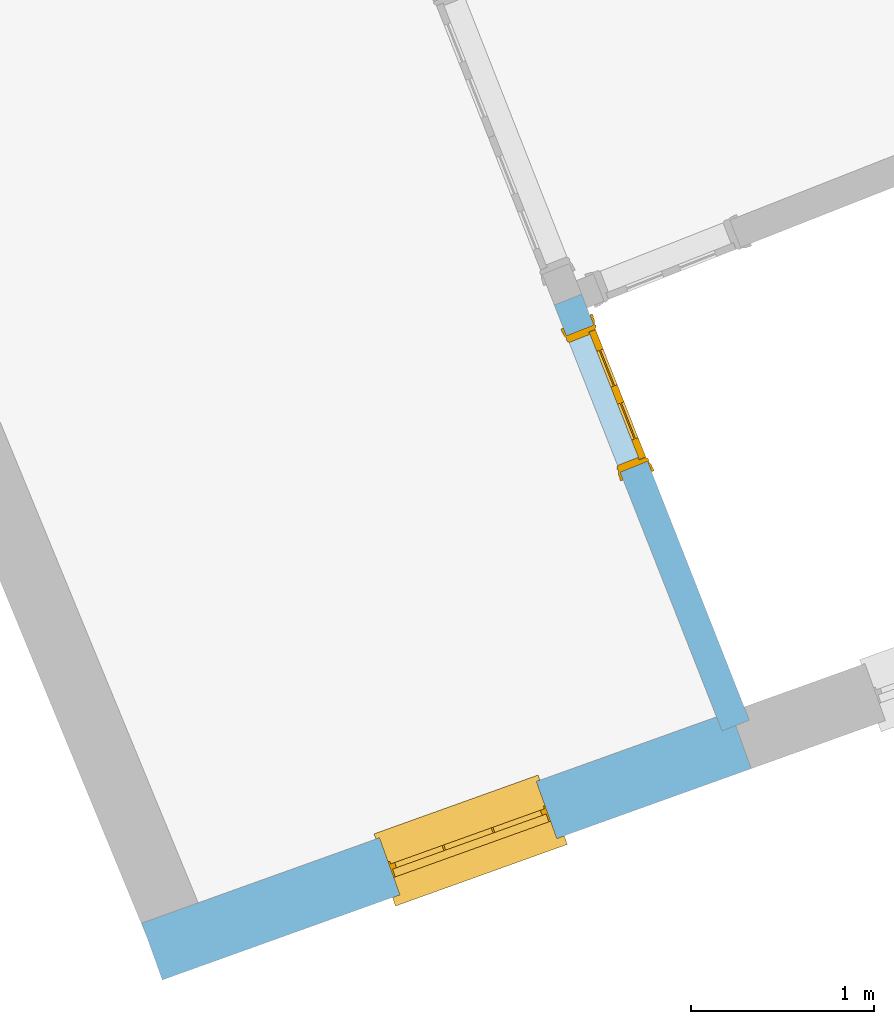
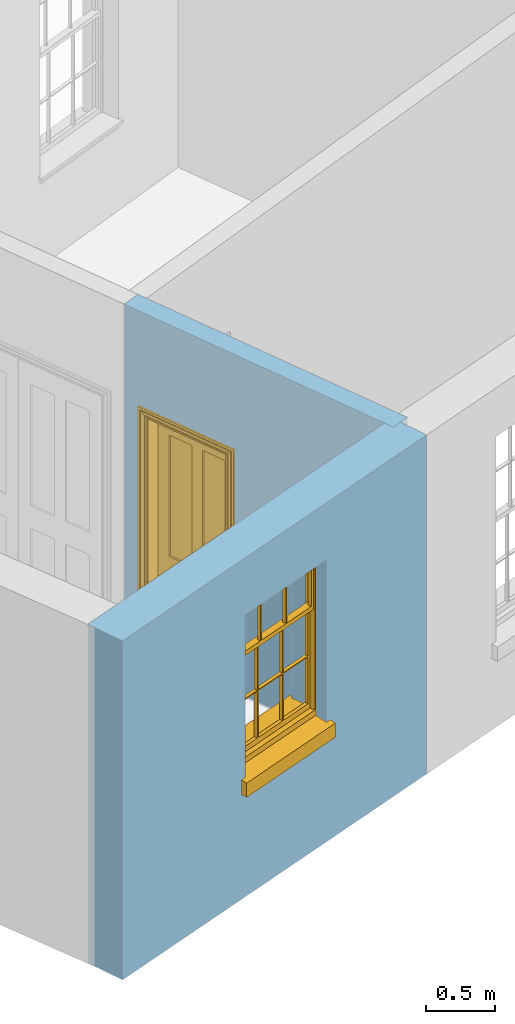
# One storey, part 2 of 6: 1 door, 1 window, 2 openings, plus 2 elements that do not belong to this part.
"""IFC2X3 building model written with IfcOpenShell, lengths in metres."""

from ifc_helpers import new_model, si_unit, frame, origin, place, context, subcontext, project, spatial, polyline, outline, extrude, faceted_brep, material, layer, layer_set, layer_usage, element, fill, save


model = new_model("IFC2X3")

# Units and contexts
model_context = context("Model", 3, world=origin())
body_context = subcontext(model_context, "Body", "Model", "MODEL_VIEW")
ifc_project = project(units=[si_unit("PLANEANGLEUNIT", "RADIAN"), si_unit("MASSUNIT", "GRAM", prefix="KILO"), si_unit("FORCEUNIT", "NEWTON", prefix="KILO"), si_unit("LENGTHUNIT", "METRE")], contexts=[model_context])

# Site, building, storey
site_placement = place(None, origin())
site = spatial("IfcSite", under=ifc_project, at=site_placement, CompositionType="ELEMENT")
building_placement = place(None, origin())
building = spatial("IfcBuilding", under=site, at=building_placement, Name="Building plot-4", CompositionType="ELEMENT")
storey_placement = place(None, frame((0.0, 0.0, 6.45)))
storey = spatial("IfcBuildingStorey", under=building, at=storey_placement, Name="Floor 1", CompositionType="ELEMENT", Elevation=6.45)

# Wall, opening, window
ifc_material_1 = material(Name="Masonry")
ifc_layer_1 = layer(ifc_material_1, 0.33, ventilated=False)
ifc_layer_set_1 = layer_set([ifc_layer_1], Name="My Wall")
ifc_layer_usage_1 = layer_usage(ifc_layer_set_1, "AXIS2", "NEGATIVE", 0.08)
wall_1_placement = place(storey_placement, origin())
wall_1 = element("IfcWallStandardCase", 1, at=wall_1_placement, inside=storey, material=ifc_layer_usage_1, Name="exterior", context=body_context, shape_type="SweptSolid", body=[
    extrude(outline(polyline([(46.3816931332496, 45.3875319065881), (46.4931346698559, 45.0769183461649), (49.70423854185, 46.2289940933087), (49.5927970052436, 46.539607653732), (46.3816931332496, 45.3875319065881)])), origin(), (0.0, 0.0, 1.0), 3.0),
])
opening_1_placement = place(storey_placement, frame((0.0, 0.0, 1.05)))
opening_1 = element("IfcOpeningElement", 2, at=opening_1_placement, cuts=wall_1, Name="Opening", ObjectType="Opening", context=body_context, shape_type="SweptSolid", body=[
    extrude(outline(polyline([(47.7880730454297, 45.5415146831305), (48.6446134696272, 45.8488231628631), (48.5331719330208, 46.1594367232864), (47.6766315088233, 45.8521282435537), (47.7880730454297, 45.5415146831305)])), origin(), (0.0, 0.0, 1.0), 1.445),
])
window_placement = place(storey_placement, frame((47.7036476389097, 45.7768279864814, 1.05), z_axis=(0.0, 0.0, 1.0), x_axis=(0.856540424197469, 0.307308479732683, 0.0)))
window = element("IfcWindow", 3, at=window_placement, inside=storey, Name="kitchen outside window", OverallHeight=1.445, OverallWidth=0.91, context=body_context, shape_type="Brep", held_by="IfcProductRepresentation", body=[
    faceted_brep([(0.876875, -0.105, 0.999097), (0.876875, -0.105, 1.411875), (0.9, -0.105, 1.435), (0.033125, -0.105, 1.411875), (0.033125, -0.105, 0.999097), (0.01, -0.105, 1.435), (0.033125, -0.135, 1.411875), (0.01, -0.135, 1.435), (0.033125, -0.135, 0.999097), (0.876875, -0.135, 1.411875), (0.876875, -0.135, 0.999097), (0.9, -0.135, 1.435), (0.033125, -0.105, 0.960972), (0.01, -0.105, 0.960972), (0.033125, -0.105, 0.548195), (0.876875, -0.105, 0.960972), (0.876875, -0.105, 0.548195), (0.9, -0.105, 0.960972), (0.876875, -0.105, 0.538195), (0.876875, -0.105, 0.125417), (0.9, -0.105, 0.077167), (0.033125, -0.105, 0.125417), (0.033125, -0.105, 0.538195), (0.01, -0.105, 0.077167), (0.9, -0.135, 0.960972), (0.01, -0.135, 0.960972), (-0.0425, -0.25, 0.01), (-0.0425, -0.3, 0.001667), (0.0, -0.25, 0.01), (0.9525, -0.25, 0.01), (0.91, -0.25, 0.01), (0.9525, -0.3, 0.001667), (-0.02, 0.08, 0.077167), (0.0, 0.08, 0.077167), (-0.02, 0.11, 0.077167), (0.0, -0.06, 0.077167), (0.01, -0.06, 0.077167), (0.91, -0.06, 0.077167), (0.91, 0.08, 0.077167), (0.9, -0.06, 0.077167), (0.93, 0.08, 0.077167), (0.93, 0.11, 0.077167), (0.01, -0.105, 0.999097), (0.01, -0.075, 0.999097), (0.9, -0.105, 0.999097), (0.9, -0.075, 0.999097), (0.876875, -0.075, 0.125417), (0.876875, -0.075, 0.538195), (0.9, -0.075, 0.077167), (0.876875, -0.075, 0.548195), (0.876875, -0.075, 0.960972), (0.033125, -0.075, 0.125417), (0.01, -0.075, 0.077167), (0.033125, -0.075, 0.538195), (0.033125, -0.075, 0.960972), (0.033125, -0.075, 0.548195), (-0.02, 0.08, 0.052167), (-0.02, 0.11, 0.052167), (0.93, 0.11, 0.052167), (0.93, 0.08, 0.052167), (0.91, 0.08, 0.052167), (0.0, 0.08, 0.052167), (0.91, -0.15, 0.026667), (0.0, -0.15, 0.026667), (-0.0425, -0.3, -0.123333), (0.9525, -0.3, -0.123333), (-0.0425, -0.25, -0.123333), (0.9525, -0.25, -0.123333), (0.01, -0.06, 1.435), (0.9, -0.06, 1.435), (0.0, -0.06, 1.445), (0.91, -0.06, 1.445), (0.01, -0.15, 0.077167), (0.9, -0.15, 0.077167), (0.592292, -0.105, 0.125417), (0.592292, -0.075, 0.125417), (0.317708, -0.075, 0.125417), (0.317708, -0.105, 0.125417), (0.592292, -0.105, 0.548195), (0.317708, -0.105, 0.548195), (0.317708, -0.105, 0.538195), (0.592292, -0.105, 0.538195), (0.592292, -0.075, 0.548195), (0.317708, -0.075, 0.548195), (0.602292, -0.075, 0.548195), (0.602292, -0.105, 0.548195), (0.317708, -0.075, 0.538195), (0.307708, -0.075, 0.125417), (0.307708, -0.075, 0.538195), (0.602292, -0.075, 0.538195), (0.602292, -0.075, 0.125417), (0.592292, -0.075, 0.538195), (0.307708, -0.075, 0.548195), (0.317708, -0.075, 0.960972), (0.307708, -0.075, 0.960972), (0.602292, -0.075, 0.960972), (0.592292, -0.075, 0.960972), (0.307708, -0.105, 0.538195), (0.307708, -0.105, 0.125417), (0.307708, -0.105, 0.548195), (0.307708, -0.105, 0.960972), (0.592292, -0.105, 0.960972), (0.317708, -0.105, 0.960972), (0.602292, -0.105, 0.960972), (0.602292, -0.105, 0.538195), (0.602292, -0.105, 0.125417), (0.317708, -0.135, 1.411875), (0.307708, -0.135, 1.411875), (0.307708, -0.135, 0.999097), (0.317708, -0.135, 0.999097), (0.602292, -0.135, 1.411875), (0.592292, -0.135, 1.411875), (0.592292, -0.135, 0.999097), (0.602292, -0.135, 0.999097), (0.317708, -0.105, 0.999097), (0.307708, -0.105, 0.999097), (0.307708, -0.105, 1.411875), (0.317708, -0.105, 1.411875), (0.602292, -0.105, 0.999097), (0.592292, -0.105, 0.999097), (0.592292, -0.105, 1.411875), (0.602292, -0.105, 1.411875), (0.91, -0.15, 1.445), (0.9, -0.15, 1.435), (0.01, -0.15, 1.435), (0.0, -0.15, 1.445), (0.91, -0.25, 0.0), (0.0, -0.25, 0.0), (0.91, 0.08, 0.0), (0.0, 0.08, 0.0)], [[[0, 1, 2]], [[3, 4, 5]], [[6, 7, 8]], [[9, 10, 11]], [[12, 13, 14]], [[15, 16, 17]], [[18, 19, 20]], [[21, 22, 23]], [[24, 15, 17]], [[13, 12, 25]], [[26, 27, 28]], [[29, 30, 31]], [[32, 33, 34]], [[35, 36, 33]], [[37, 38, 39]], [[40, 41, 38]], [[42, 4, 43]], [[44, 45, 0]], [[46, 47, 48]], [[49, 50, 45]], [[51, 52, 53]], [[54, 55, 43]], [[38, 33, 36, 39]], [[41, 34, 33, 38]], [[56, 32, 34, 57]], [[57, 34, 41, 58]], [[58, 41, 40, 59]], [[57, 58, 60, 61]], [[52, 48, 39, 36]], [[62, 63, 28, 30]], [[27, 31, 30, 28]], [[27, 64, 65, 31]], [[66, 67, 65, 64]], [[2, 5, 68, 69]], [[68, 70, 71, 69]], [[20, 23, 72, 73]], [[73, 72, 63, 62]], [[74, 75, 76, 77]], [[78, 79, 80, 81]], [[78, 82, 83, 79]], [[16, 49, 84, 85]], [[86, 76, 87, 88]], [[89, 90, 75, 91]], [[92, 88, 53, 55]], [[82, 91, 86, 83]], [[93, 83, 92, 94]], [[95, 84, 82, 96]], [[89, 84, 49, 47]], [[97, 88, 87, 98]], [[22, 53, 88, 97]], [[81, 91, 75, 74]], [[80, 86, 91, 81]], [[77, 76, 86, 80]], [[99, 92, 55, 14]], [[100, 94, 92, 99]], [[101, 96, 82, 78]], [[79, 83, 93, 102]], [[85, 84, 95, 103]], [[104, 89, 47, 18]], [[105, 90, 89, 104]], [[104, 18, 16, 85]], [[80, 97, 98, 77]], [[104, 81, 74, 105]], [[103, 101, 78, 85]], [[99, 14, 22, 97]], [[102, 100, 99, 79]], [[106, 107, 108, 109]], [[110, 111, 112, 113]], [[114, 115, 116, 117]], [[118, 119, 120, 121]], [[107, 116, 115, 108]], [[111, 120, 119, 112]], [[109, 114, 117, 106]], [[113, 118, 121, 110]], [[85, 78, 81, 104]], [[84, 89, 91, 82]], [[83, 86, 88, 92]], [[79, 99, 97, 80]], [[109, 112, 119, 114]], [[102, 93, 96, 101]], [[106, 117, 120, 111]], [[98, 87, 51, 21]], [[6, 3, 116, 107]], [[110, 121, 1, 9]], [[19, 46, 90, 105]], [[26, 66, 64, 27]], [[29, 31, 65, 67]], [[25, 24, 112, 109]], [[11, 7, 106, 111]], [[75, 48, 52, 76]], [[43, 45, 96, 93]], [[45, 43, 114, 119]], [[5, 2, 120, 117]], [[24, 25, 102, 101]], [[42, 5, 4]], [[2, 44, 0]], [[49, 45, 48, 47]], [[52, 43, 55, 53]], [[14, 13, 23, 22]], [[20, 17, 16, 18]], [[24, 11, 10]], [[25, 8, 7]], [[8, 4, 3, 6]], [[9, 1, 0, 10]], [[15, 50, 49, 16]], [[18, 47, 46, 19]], [[21, 51, 53, 22]], [[14, 55, 54, 12]], [[44, 2, 69, 45]], [[68, 5, 42, 43]], [[36, 35, 70, 68]], [[39, 69, 71, 37]], [[62, 122, 123, 73]], [[63, 72, 124, 125]], [[8, 108, 115, 4]], [[113, 10, 0, 118]], [[94, 100, 12, 54]], [[17, 20, 73, 24]], [[72, 23, 13, 25]], [[52, 36, 68, 43]], [[69, 39, 48, 45]], [[11, 24, 73, 123]], [[7, 124, 72, 25]], [[23, 77, 98]], [[98, 21, 23]], [[105, 74, 20]], [[20, 19, 105]], [[20, 74, 77, 23]], [[113, 112, 24]], [[24, 10, 113]], [[25, 109, 108]], [[108, 8, 25]], [[110, 9, 11]], [[11, 111, 110]], [[7, 6, 107]], [[107, 106, 7]], [[5, 117, 116]], [[116, 3, 5]], [[121, 120, 2]], [[2, 1, 121]], [[11, 123, 124, 7]], [[122, 125, 124, 123]], [[43, 93, 94]], [[94, 54, 43]], [[96, 45, 95]], [[50, 95, 45]], [[15, 103, 95, 50]], [[48, 75, 90]], [[90, 46, 48]], [[87, 76, 52]], [[52, 51, 87]], [[103, 15, 24]], [[24, 101, 103]], [[100, 102, 25]], [[25, 12, 100]], [[115, 114, 43]], [[43, 4, 115]], [[118, 0, 45]], [[45, 119, 118]], [[71, 70, 125, 122]], [[70, 35, 63, 125]], [[122, 62, 37, 71]], [[126, 67, 66, 127]], [[60, 58, 59]], [[38, 60, 59, 40]], [[61, 56, 57]], [[32, 56, 61, 33]], [[61, 60, 128, 129]], [[62, 60, 38, 37]], [[126, 128, 60, 62]], [[33, 61, 63, 35]], [[61, 129, 127, 63]], [[128, 126, 127, 129]], [[28, 127, 66, 26]], [[63, 127, 28]], [[29, 67, 126, 30]], [[30, 126, 62]]]),
])
fill(opening_1, window)

# Wall, opening, door
ifc_material_2 = material(Name="Masonry")
ifc_layer_2 = layer(ifc_material_2, 0.16, ventilated=False)
ifc_layer_set_2 = layer_set([ifc_layer_2], Name="My Wall")
ifc_layer_usage_2 = layer_usage(ifc_layer_set_2, "AXIS2", "NEGATIVE", 0.08)
wall_2_placement = place(storey_placement, origin())
wall_2 = element("IfcWallStandardCase", 4, at=wall_2_placement, inside=storey, material=ifc_layer_usage_2, Name="interior", context=body_context, shape_type="SweptSolid", body=[
    extrude(outline(polyline([(48.7797136330055, 48.8158373917891), (48.6308422340991, 48.7572088442405), (49.5453774358768, 46.4349931228854), (49.6942488347832, 46.493621670434), (48.7797136330055, 48.8158373917891)])), origin(), (0.0, 0.0, 1.0), 3.0),
])
opening_2_placement = place(storey_placement, frame((0.0, 0.0, 0.0199999999999996)))
opening_2 = element("IfcOpeningElement", 5, at=opening_2_placement, cuts=wall_2, Name="Opening", ObjectType="Opening", context=body_context, shape_type="SweptSolid", body=[
    extrude(outline(polyline([(48.6967993500914, 48.5897285204708), (48.9899420878348, 47.8453715259391), (49.1388134867411, 47.9040000734878), (48.8456707489977, 48.6483570680195), (48.6967993500914, 48.5897285204708)])), origin(), (0.0, 0.0, 1.0), 2.1),
])
door_placement = place(storey_placement, frame((48.7712350495446, 48.6190427942452, 0.0199999999999996), z_axis=(0.0, 0.0, 1.0), x_axis=(0.293142737743374, -0.744356994531742, 0.0)))
door = element("IfcDoor", 6, at=door_placement, inside=storey, Name="kitchen inside door", OverallHeight=2.1, OverallWidth=0.8, context=body_context, shape_type="Brep", held_by="IfcProductRepresentation", body=[
    faceted_brep([(0.773, 0.08, 1.895), (0.66, 0.08, 1.895), (0.66, 0.08, 2.073), (0.773, 0.08, 2.073), (0.773, 0.08, 0.82), (0.66, 0.08, 0.82), (0.45, 0.08, 1.895), (0.45, 0.08, 2.073), (0.773, 0.08, 0.62), (0.66, 0.08, 0.62), (0.66, 0.065, 0.82), (0.66, 0.065, 1.895), (0.45, 0.065, 1.895), (0.35, 0.08, 1.895), (0.35, 0.08, 2.073), (0.773, 0.08, 0.225), (0.66, 0.08, 0.225), (0.45, 0.08, 0.62), (0.45, 0.08, 0.82), (0.45, 0.065, 0.82), (0.35, 0.08, 0.82), (0.14, 0.08, 2.073), (0.14, 0.08, 1.895), (0.773, 0.08, 0.0), (0.66, 0.08, 0.0), (0.66, 0.065, 0.225), (0.66, 0.065, 0.62), (0.45, 0.065, 0.62), (0.35, 0.08, 0.62), (0.35, 0.065, 0.82), (0.35, 0.065, 1.895), (0.14, 0.065, 1.895), (0.027, 0.08, 2.073), (0.027, 0.08, 1.895), (0.773, 0.042, 0.0), (0.66, 0.042, 0.0), (0.45, 0.08, 0.0), (0.45, 0.08, 0.225), (0.45, 0.065, 0.225), (0.35, 0.08, 0.225), (0.14, 0.08, 0.82), (0.14, 0.08, 0.62), (0.14, 0.065, 0.82), (0.027, 0.08, 0.82), (0.773, 0.042, 0.225), (0.66, 0.042, 0.225), (0.45, 0.042, 0.0), (0.35, 0.08, 0.0), (0.35, 0.065, 0.225), (0.35, 0.065, 0.62), (0.14, 0.065, 0.62), (0.027, 0.08, 0.62), (0.773, 0.042, 0.62), (0.66, 0.042, 0.62), (0.45, 0.042, 0.225), (0.35, 0.042, 0.0), (0.14, 0.08, 0.225), (0.14, 0.08, 0.0), (0.14, 0.065, 0.225), (0.027, 0.08, 0.225), (0.773, 0.042, 0.82), (0.66, 0.042, 0.82), (0.66, 0.057, 0.62), (0.66, 0.057, 0.225), (0.45, 0.057, 0.225), (0.35, 0.042, 0.225), (0.14, 0.042, 0.0), (0.027, 0.08, 0.0), (0.773, 0.042, 1.895), (0.66, 0.042, 1.895), (0.45, 0.042, 0.62), (0.45, 0.042, 0.82), (0.45, 0.057, 0.62), (0.35, 0.042, 0.62), (0.14, 0.042, 0.225), (0.027, 0.042, 0.0), (0.773, 0.042, 2.073), (0.66, 0.042, 2.073), (0.66, 0.057, 1.895), (0.66, 0.057, 0.82), (0.45, 0.057, 0.82), (0.35, 0.042, 0.82), (0.35, 0.057, 0.62), (0.35, 0.057, 0.225), (0.14, 0.057, 0.225), (0.027, 0.042, 0.225), (0.45, 0.042, 1.895), (0.45, 0.042, 2.073), (0.45, 0.057, 1.895), (0.35, 0.042, 1.895), (0.14, 0.042, 0.82), (0.14, 0.042, 0.62), (0.14, 0.057, 0.62), (0.027, 0.042, 0.62), (0.35, 0.042, 2.073), (0.35, 0.057, 1.895), (0.35, 0.057, 0.82), (0.14, 0.057, 0.82), (0.027, 0.042, 0.82), (0.14, 0.042, 2.073), (0.14, 0.042, 1.895), (0.14, 0.057, 1.895), (0.027, 0.042, 1.895), (0.027, 0.042, 2.073), (0.02, 0.085, 0.0), (0.005, 0.09, 0.0), (0.005, 0.09, 2.095), (0.02, 0.085, 2.08), (0.02, 0.08, 0.0), (0.0, 0.085, 0.0), (0.0, 0.085, 2.1), (0.795, 0.09, 2.095), (0.78, 0.085, 2.08), (0.02, 0.08, 2.08), (0.0, 0.08, 0.0), (-0.032, 0.095, 0.0), (-0.032, 0.095, 2.132), (0.8, 0.085, 2.1), (0.795, 0.09, 0.0), (0.78, 0.085, 0.0), (0.78, 0.08, 2.08), (0.04, 0.04, 0.0), (0.025, 0.04, 0.0), (0.025, 0.04, 2.075), (0.04, 0.04, 2.06), (-0.04, 0.09, 0.0), (-0.04, 0.09, 2.14), (0.832, 0.095, 2.132), (0.8, 0.085, 0.0), (0.78, 0.08, 0.0), (0.8, 0.08, 0.0), (0.86, 0.08, 0.0), (0.86, 0.08, 2.16), (0.8, 0.08, 2.1), (-0.06, 0.08, 2.16), (0.0, 0.08, 2.1), (-0.06, 0.08, 0.0), (-0.04, 0.095, 0.0), (-0.04, 0.095, 2.14), (0.84, 0.09, 2.14), (0.832, 0.095, 0.0), (0.84, 0.09, 0.0), (0.86, 0.095, 0.0), (0.86, 0.095, 2.16), (-0.06, 0.095, 2.16), (-0.06, 0.095, 0.0), (0.84, 0.095, 0.0), (0.84, 0.095, 2.14), (-0.025, -0.095, 0.0), (-0.025, -0.09, 0.0), (-0.025, -0.09, 2.125), (-0.025, -0.095, 2.125), (-0.017, -0.095, 0.0), (-0.017, -0.095, 2.117), (0.825, -0.09, 2.125), (0.825, -0.095, 2.125), (0.825, -0.095, 0.0), (0.845, -0.095, 0.0), (-0.045, -0.095, 2.145), (-0.045, -0.095, 0.0), (0.845, -0.095, 2.145), (0.015, -0.085, 0.0), (0.015, -0.085, 2.085), (0.817, -0.095, 2.117), (0.825, -0.09, 0.0), (0.845, -0.08, 0.0), (0.845, -0.08, 2.145), (-0.045, -0.08, 2.145), (-0.045, -0.08, 0.0), (0.02, -0.09, 0.0), (0.02, -0.09, 2.08), (0.785, -0.085, 2.085), (0.817, -0.095, 0.0), (0.8, -0.08, 0.0), (0.8, -0.08, 2.1), (0.0, -0.08, 2.1), (0.0, -0.08, 0.0), (0.035, -0.085, 0.0), (0.035, -0.085, 2.065), (0.78, -0.09, 2.08), (0.785, -0.085, 0.0), (0.775, 0.04, 2.075), (0.76, 0.04, 2.06), (0.035, -0.08, 2.065), (0.035, -0.08, 0.0), (0.765, -0.085, 2.065), (0.78, -0.09, 0.0), (0.765, -0.08, 0.0), (0.765, -0.08, 2.065), (0.765, -0.085, 0.0), (0.04, -0.08, 2.06), (0.04, -0.08, 0.0), (0.76, -0.08, 2.06), (0.76, -0.08, 0.0), (0.76, 0.04, 0.0), (0.775, 0.04, 0.0), (0.025, 0.08, 0.0), (0.025, 0.08, 2.075), (0.775, 0.08, 0.0), (0.775, 0.08, 2.075)], [[[0, 1, 2, 3]], [[1, 0, 4, 5]], [[1, 6, 7, 2]], [[8, 9, 5, 4]], [[1, 5, 10, 11]], [[6, 1, 11, 12]], [[6, 13, 14, 7]], [[15, 16, 9, 8]], [[9, 17, 18, 5]], [[5, 18, 19, 10]], [[10, 19, 12, 11]], [[18, 6, 12, 19]], [[18, 20, 13, 6]], [[21, 14, 13, 22]], [[23, 24, 16, 15]], [[9, 16, 25, 26]], [[17, 9, 26, 27]], [[17, 28, 20, 18]], [[13, 20, 29, 30]], [[22, 13, 30, 31]], [[32, 21, 22, 33]], [[34, 35, 24, 23]], [[24, 36, 37, 16]], [[16, 37, 38, 25]], [[25, 38, 27, 26]], [[37, 17, 27, 38]], [[37, 39, 28, 17]], [[40, 20, 28, 41]], [[20, 40, 42, 29]], [[31, 30, 29, 42]], [[40, 22, 31, 42]], [[33, 22, 40, 43]], [[35, 34, 44, 45]], [[35, 46, 36, 24]], [[36, 47, 39, 37]], [[28, 39, 48, 49]], [[41, 28, 49, 50]], [[43, 40, 41, 51]], [[45, 44, 52, 53]], [[46, 35, 45, 54]], [[46, 55, 47, 36]], [[56, 39, 47, 57]], [[39, 56, 58, 48]], [[50, 49, 48, 58]], [[56, 41, 50, 58]], [[51, 41, 56, 59]], [[53, 52, 60, 61]], [[45, 53, 62, 63]], [[54, 45, 63, 64]], [[55, 46, 54, 65]], [[55, 66, 57, 47]], [[59, 56, 57, 67]], [[61, 60, 68, 69]], [[70, 53, 61, 71]], [[53, 70, 72, 62]], [[72, 64, 63, 62]], [[70, 54, 64, 72]], [[65, 54, 70, 73]], [[65, 74, 66, 55]], [[67, 57, 66, 75]], [[69, 68, 76, 77]], [[61, 69, 78, 79]], [[71, 61, 79, 80]], [[73, 70, 71, 81]], [[65, 73, 82, 83]], [[74, 65, 83, 84]], [[74, 85, 75, 66]], [[86, 69, 77, 87]], [[69, 86, 88, 78]], [[88, 80, 79, 78]], [[86, 71, 80, 88]], [[81, 71, 86, 89]], [[73, 81, 90, 91]], [[73, 91, 92, 82]], [[83, 82, 92, 84]], [[91, 74, 84, 92]], [[91, 93, 85, 74]], [[89, 86, 87, 94]], [[81, 89, 95, 96]], [[90, 81, 96, 97]], [[90, 98, 93, 91]], [[94, 99, 100, 89]], [[89, 100, 101, 95]], [[101, 97, 96, 95]], [[100, 90, 97, 101]], [[100, 102, 98, 90]], [[99, 103, 102, 100]], [[32, 103, 99, 21]], [[102, 103, 32, 33]], [[98, 102, 33, 43]], [[21, 99, 94, 14]], [[94, 87, 7, 14]], [[7, 87, 77, 2]], [[76, 3, 2, 77]], [[43, 51, 93, 98]], [[51, 59, 85, 93]], [[67, 75, 85, 59]], [[34, 23, 15, 44]], [[44, 15, 8, 52]], [[52, 8, 4, 60]], [[0, 68, 60, 4]], [[0, 3, 76, 68]], [[104, 105, 106, 107]], [[104, 108, 109, 105]], [[105, 109, 110, 106]], [[107, 106, 111, 112]], [[107, 113, 108, 104]], [[114, 109, 108]], [[109, 115, 116, 110]], [[106, 110, 117, 111]], [[112, 111, 118, 119]], [[113, 107, 112, 120]], [[121, 122, 123, 124]], [[115, 109, 114, 125]], [[115, 125, 126, 116]], [[110, 116, 127, 117]], [[111, 117, 128, 118]], [[118, 128, 129, 119]], [[120, 112, 119, 129]], [[130, 129, 128]], [[130, 131, 132, 133]], [[133, 132, 134, 135]], [[135, 134, 136, 114]], [[136, 125, 114]], [[125, 137, 138, 126]], [[116, 126, 139, 127]], [[117, 127, 140, 128]], [[141, 130, 128, 140]], [[131, 130, 141]], [[131, 142, 143, 132]], [[132, 143, 144, 134]], [[134, 144, 145, 136]], [[137, 125, 136, 145]], [[143, 142, 146]], [[143, 146, 147]], [[137, 145, 144]], [[143, 147, 138]], [[138, 137, 144]], [[143, 138, 144]], [[126, 138, 147, 139]], [[127, 139, 141, 140]], [[142, 131, 141, 146]], [[139, 147, 146, 141]], [[148, 149, 150, 151]], [[149, 152, 153, 150]], [[151, 150, 154, 155]], [[155, 156, 157]], [[158, 159, 148]], [[158, 148, 151]], [[155, 157, 160]], [[158, 151, 155]], [[155, 160, 158]], [[152, 161, 162, 153]], [[150, 153, 163, 154]], [[155, 154, 164, 156]], [[156, 164, 165, 157]], [[157, 165, 166, 160]], [[160, 166, 167, 158]], [[158, 167, 168, 159]], [[161, 169, 170, 162]], [[153, 162, 171, 163]], [[154, 163, 172, 164]], [[165, 164, 173]], [[165, 173, 174, 166]], [[166, 174, 175, 167]], [[167, 175, 176, 168]], [[169, 177, 178, 170]], [[162, 170, 179, 171]], [[163, 171, 180, 172]], [[172, 180, 173, 164]], [[124, 123, 181, 182]], [[183, 178, 177, 184]], [[170, 178, 185, 179]], [[171, 179, 186, 180]], [[187, 173, 180]], [[185, 188, 187, 189]], [[188, 185, 178, 183]], [[179, 185, 189, 186]], [[189, 187, 180, 186]], [[190, 183, 184, 191]], [[192, 188, 183, 190]], [[191, 184, 122, 121]], [[124, 190, 191, 121]], [[193, 187, 188, 192]], [[182, 192, 190, 124]], [[184, 176, 122]], [[194, 195, 187, 193]], [[192, 182, 194, 193]], [[161, 176, 184]], [[114, 108, 122, 176]], [[173, 187, 195]], [[152, 149, 176, 161]], [[169, 161, 184, 177]], [[196, 122, 108]], [[176, 175, 135, 114]], [[173, 195, 129, 130]], [[176, 149, 168]], [[123, 122, 196, 197]], [[196, 108, 113, 197]], [[175, 174, 133, 135]], [[198, 129, 195]], [[133, 174, 173, 130]], [[159, 168, 149, 148]], [[181, 123, 197, 199]], [[197, 113, 120, 199]], [[199, 120, 129, 198]], [[195, 181, 199, 198]], [[195, 194, 182, 181]]]),
])
fill(opening_2, door)

save(model, "model.ifc")
